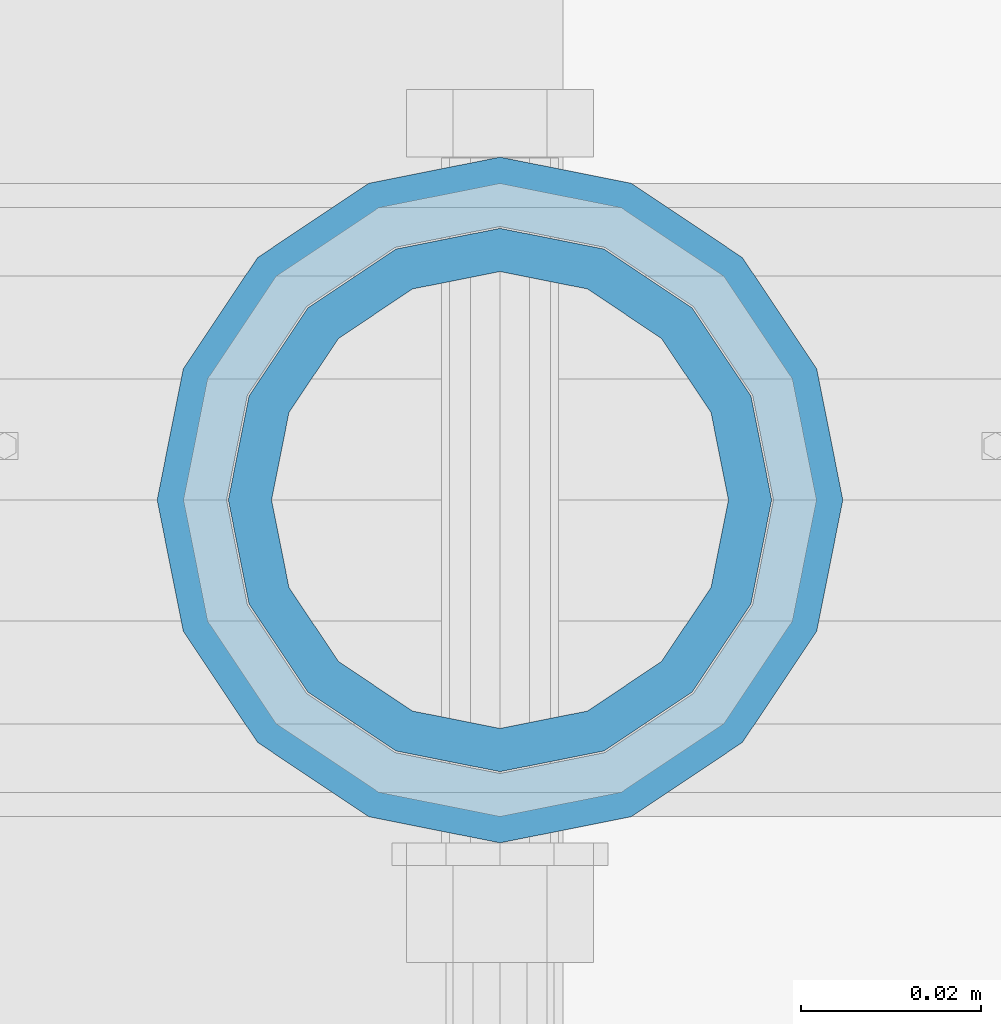
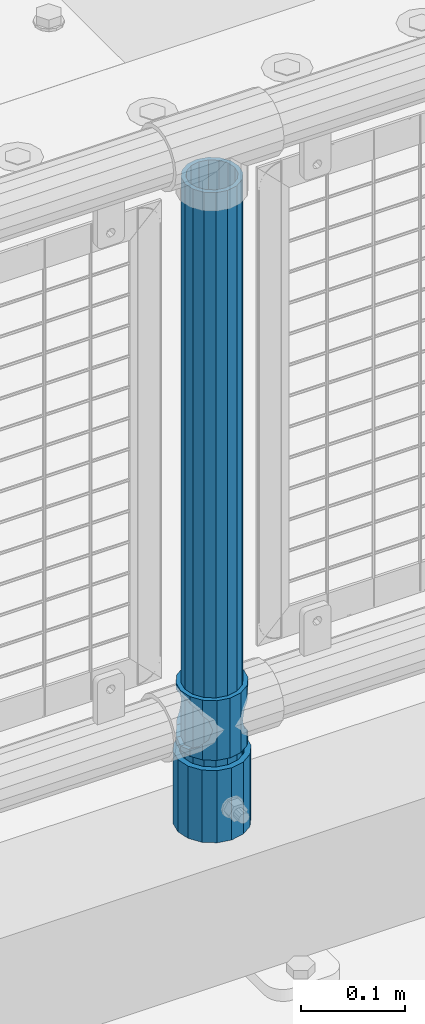
# One storey, part 78 of 219: 3 columns.
"""IFC2X3 building model written with IfcOpenShell, lengths in millimetres."""

from ifc_helpers import new_model, si_unit, frame, origin_with_axes, place, context, subcontext, project, spatial, faceted_brep, material, type_object, element, save


model = new_model("IFC2X3")

# Units and contexts
model_context = context("Model", 3, precision=1e-05, world=origin_with_axes())
body_context = subcontext(model_context, "Body", "Model", "MODEL_VIEW")
ifc_project = project(units=[si_unit("LENGTHUNIT", "METRE", prefix="MILLI"), si_unit("AREAUNIT", "SQUARE_METRE"), si_unit("VOLUMEUNIT", "CUBIC_METRE"), si_unit("MASSUNIT", "GRAM", prefix="KILO"), si_unit("TIMEUNIT", "SECOND"), si_unit("PLANEANGLEUNIT", "RADIAN"), si_unit("SOLIDANGLEUNIT", "STERADIAN"), si_unit("THERMODYNAMICTEMPERATUREUNIT", "DEGREE_CELSIUS"), si_unit("LUMINOUSINTENSITYUNIT", "LUMEN")], contexts=[model_context])

# Site, building, storey
site_placement = place(None, origin_with_axes())
site = spatial("IfcSite", under=ifc_project, at=site_placement, CompositionType="ELEMENT")
building_placement = place(site_placement, origin_with_axes())
building = spatial("IfcBuilding", under=site, at=building_placement, Name="Standard", CompositionType="ELEMENT")
storey_placement = place(building_placement, origin_with_axes())
storey = spatial("IfcBuildingStorey", under=building, at=storey_placement, Name="Undefined", CompositionType="ELEMENT", Elevation=0.0)

# Columns
ifc_material_1 = material(Name="Misc_Undefined")
column_type_1 = type_object("IfcColumnType", PredefinedType="NOTDEFINED")
column_1_placement = place(storey_placement, frame((7253.0, 31664.5, 263.02), z_axis=(-1.0, 0.0, 0.0), x_axis=(0.0, 0.0, 1.0)))
element("IfcColumn", 1, at=column_1_placement, inside=storey, type_object=column_type_1, material=ifc_material_1, context=body_context, shape_type="Brep", body=[
    faceted_brep([(56.6106908090114, 21.46069080901, -21.4606908090118), (56.6106908090114, 21.46069080901, -27.1226768591096), (61.9623795176703, 13.4513226476338, -32.4743655677721), (63.1897438117172, 11.614442172282, -32.8397438117172), (63.1897438117172, 11.614442172282, -28.0397438117179), (46.7644421722801, 28.0397438117179, -11.6144421722802), (46.7644421722801, 28.0397438117179, -20.0882031229849), (51.5310424080006, 24.8548033587067, -24.8548033587067), (35.1499999999996, 30.35, 0.0), (35.1499999999996, 30.3499999999985, -16.6306603983739), (23.5355578277192, 28.0397438117179, -11.6144421722802), (23.5355578277192, 28.0397438117179, -20.0882031229849), (13.6893091909879, 21.46069080901, -21.4606908090118), (13.6893091909879, 21.46069080901, -27.1226768591096), (18.7689575919987, 24.8548033587067, -24.8548033587067), (7.11025618828211, 11.614442172282, -28.0397438117179), (7.11025618828211, 11.614442172282, -32.8397438117172), (8.33762048232455, 13.4513226476338, -32.4743655677721), (4.79999999999961, 0.0, -30.3500000000004), (4.79999999999961, 0.0, -35.1499999999996), (7.11025618828211, -11.614442172282, -28.0397438117179), (7.11025618828211, -11.614442172282, -32.839743811719), (13.6893091909879, -21.46069080901, -21.4606908090118), (13.6893091909879, -21.46069080901, -27.1226768591077), (8.33762048232455, -13.4513226476338, -32.4743655677721), (23.5355578277191, -28.0397438117179, -11.6144421722802), (23.5355578277191, -28.0397438117179, -20.0882031229739), (18.7689575919921, -24.8548033587067, -24.8548033587067), (35.1499999999996, -30.35, 0.0), (35.1499999999996, -30.3499999999985, -16.6306603983649), (46.7644421722801, -28.0397438117179, -11.6144421722802), (46.7644421722801, -28.0397438117179, -20.0882031229739), (56.6106908090114, -21.46069080901, -21.4606908090118), (56.6106908090114, -21.46069080901, -27.1226768591077), (51.5310424080006, -24.8548033587067, -24.8548033587067), (63.1897438117172, -11.614442172282, -28.0397438117179), (63.1897438117172, -11.614442172282, -32.839743811719), (61.9623795176747, -13.4513226476338, -32.4743655677721), (65.4999999999997, 0.0, -30.3500000000004), (65.4999999999997, 0.0, -35.1499999999996), (0.0, -28.0397438117179, -11.6144421722802), (0.0, -30.3499999999985, 0.0), (0.0, -21.46069080901, -21.4606908090118), (0.0, -11.614442172282, -28.0397438117179), (0.0, 0.0, -30.3500000000004), (0.0, 11.614442172282, -28.0397438117179), (0.0, 21.46069080901, -21.4606908090118), (0.0, 28.0397438117179, -11.6144421722802), (0.0, 30.3499999999985, 0.0), (0.0, 28.0397438117179, 11.6144421722802), (23.5355578277192, 28.0397438117179, 11.6144421722806), (0.0, 21.46069080901, 21.4606908090118), (13.6893091909879, 21.46069080901, 21.4606908090118), (0.0, 11.614442172282, 28.0397438117179), (7.11025618828211, 11.614442172282, 28.0397438117175), (0.0, 0.0, 30.3500000000004), (4.79999999999961, 0.0, 30.3499999999999), (0.0, -11.614442172282, 28.0397438117179), (7.11025618828205, -11.614442172282, 28.0397438117175), (0.0, -21.46069080901, 21.4606908090118), (13.6893091909879, -21.46069080901, 21.4606908090118), (0.0, -28.0397438117179, 11.6144421722802), (23.5355578277191, -28.0397438117179, 11.6144421722806), (0.0, -32.4743655677703, 13.4513226476338), (0.0, -35.1500000000015, 0.0), (70.2999999999993, -35.1500000000015, 0.0), (70.2999999999993, -32.4743655677703, 13.4513226476338), (0.0, 13.4513226476338, -32.4743655677721), (0.0, 24.8548033587067, -24.8548033587067), (0.0, 0.0, -35.1500000000015), (0.0, -13.4513226476338, -32.4743655677721), (0.0, -24.8548033587067, -24.8548033587067), (0.0, -24.8548033587067, 24.8548033587067), (0.0, -13.4513226476338, 32.4743655677721), (0.0, 0.0, 35.1500000000015), (0.0, 13.4513226476338, 32.4743655677721), (0.0, 24.8548033587067, 24.8548033587067), (0.0, 32.4743655677703, 13.4513226476338), (0.0, 35.1500000000015, 0.0), (0.0, 32.4743655677703, -13.4513226476338), (0.0, -32.4743655677703, -13.4513226476338), (70.2999999999993, 32.4743655677703, 13.4513226476338), (70.2999999999993, 35.1500000000015, 0.0), (70.2999999999993, 32.4743655677703, -13.4513226476338), (70.2999999999993, 24.8548033587067, -24.8548033587067), (70.2999999999993, 13.4513226476338, -32.4743655677721), (70.2999999999993, 0.0, -35.1499999999996), (70.2999999999993, -13.4513226476338, -32.4743655677721), (70.2999999999993, -24.8548033587067, -24.8548033587067), (70.2999999999993, -32.4743655677703, -13.4513226476338), (70.2999999999993, 28.0397438117179, 11.6144421722802), (70.2999999999993, 21.46069080901, 21.4606908090118), (56.6106908090114, 21.46069080901, 21.4606908090118), (46.7644421722801, 28.0397438117179, 11.6144421722806), (70.2999999999993, 11.614442172282, 28.0397438117179), (63.1897438117172, 11.614442172282, 28.0397438117175), (70.2999999999993, 0.0, 30.3500000000004), (65.4999999999997, 0.0, 30.3499999999999), (70.2999999999993, -11.614442172282, 28.0397438117179), (63.1897438117172, -11.614442172282, 28.0397438117175), (70.2999999999993, -21.46069080901, 21.4606908090118), (56.6106908090114, -21.46069080901, 21.4606908090118), (70.2999999999993, -28.0397438117179, 11.6144421722802), (46.7644421722801, -28.0397438117179, 11.6144421722806), (70.2999999999993, -11.614442172282, -28.0397438117179), (70.2999999999993, 0.0, -30.3500000000004), (70.2999999999993, -21.46069080901, -21.4606908090118), (70.2999999999993, -28.0397438117179, -11.6144421722802), (70.2999999999993, -30.3499999999985, 0.0), (70.2999999999993, 24.8548033587067, 24.8548033587067), (70.2999999999993, 13.4513226476338, 32.4743655677721), (70.2999999999993, 0.0, 35.1499999999996), (70.2999999999993, -13.4513226476338, 32.4743655677721), (70.2999999999993, -24.8548033587067, 24.8548033587067), (70.2999999999993, 30.3499999999985, 0.0), (70.2999999999993, 28.0397438117179, -11.6144421722802), (70.2999999999993, 21.46069080901, -21.4606908090118), (70.2999999999993, 11.614442172282, -28.0397438117179), (61.9623795176742, 13.4513226476338, 32.4743655677717), (51.5310424080006, 24.8548033587067, 24.8548033587072), (56.6106908090114, 21.46069080901, 27.1226768591059), (65.4999999999997, 0.0, 35.1500000000001), (63.1897438117172, 11.614442172282, 32.8397438117177), (63.1897438117172, -11.614442172282, 32.8397438117177), (61.9623795176742, -13.4513226476338, 32.4743655677717), (56.6106908090114, -21.46069080901, 27.1226768591087), (51.5310424080006, -24.8548033587067, 24.8548033587072), (18.7689575919921, -24.8548033587067, 24.8548033587072), (46.7644421722801, -28.0397438117179, 20.0882031229862), (35.1499999999996, -30.3499999999985, 16.630660398373), (23.5355578277191, -28.0397438117179, 20.0882031229862), (8.33762048232506, -13.4513226476338, 32.4743655677717), (13.6893091909879, -21.46069080901, 27.1226768591087), (4.79999999999961, 0.0, 35.1500000000001), (7.11025618828205, -11.614442172282, 32.8397438117177), (7.11025618828211, 11.614442172282, 32.8397438117177), (8.33762048232069, 13.4513226476338, 32.4743655677717), (13.6893091909879, 21.46069080901, 27.1226768591059), (18.7689575919987, 24.8548033587067, 24.8548033587072), (23.5355578277192, 28.0397438117179, 20.0882031229794), (35.1499999999996, 30.3499999999985, 16.6306603983667), (46.7644421722801, 28.0397438117179, 20.0882031229794)], [[[0, 1, 2, 3, 4]], [[5, 6, 7, 1, 0]], [[8, 9, 6, 5]], [[10, 11, 9, 8]], [[12, 13, 14, 11, 10]], [[15, 16, 17, 13, 12]], [[18, 19, 16, 15]], [[20, 21, 19, 18]], [[22, 23, 24, 21, 20]], [[25, 26, 27, 23, 22]], [[28, 29, 26, 25]], [[30, 31, 29, 28]], [[32, 33, 34, 31, 30]], [[35, 36, 37, 33, 32]], [[38, 39, 36, 35]], [[4, 3, 39, 38]], [[40, 41, 28, 25]], [[42, 40, 25, 22]], [[43, 42, 22, 20]], [[44, 43, 20, 18]], [[45, 44, 18, 15]], [[46, 45, 15, 12]], [[47, 46, 12, 10]], [[48, 47, 10, 8]], [[49, 48, 8, 50]], [[51, 49, 50, 52]], [[53, 51, 52, 54]], [[55, 53, 54, 56]], [[57, 55, 56, 58]], [[59, 57, 58, 60]], [[61, 59, 60, 62]], [[41, 61, 62, 28]], [[63, 64, 65, 66]], [[17, 67, 68, 14, 13]], [[19, 69, 67, 17, 16]], [[70, 69, 19, 21, 24]], [[71, 70, 24, 23, 27]], [[63, 72, 73, 74, 75, 76, 77, 78, 79, 68, 67, 69, 70, 71, 80, 64], [40, 42, 43, 44, 45, 46, 47, 48, 49, 51, 53, 55, 57, 59, 61, 41]], [[78, 77, 81, 82]], [[79, 78, 82, 83]], [[14, 68, 79, 83, 84, 7, 6, 9, 11]], [[84, 85, 2, 1, 7]], [[85, 86, 39, 3, 2]], [[37, 87, 88, 34, 33]], [[39, 86, 87, 37, 36]], [[34, 88, 89, 80, 71, 27, 26, 29, 31]], [[64, 80, 89, 65]], [[90, 91, 92, 93]], [[91, 94, 95, 92]], [[94, 96, 97, 95]], [[96, 98, 99, 97]], [[98, 100, 101, 99]], [[100, 102, 103, 101]], [[104, 105, 38, 35]], [[106, 104, 35, 32]], [[107, 106, 32, 30]], [[108, 107, 30, 28]], [[102, 108, 28, 103]], [[88, 87, 86, 85, 84, 83, 82, 81, 109, 110, 111, 112, 113, 66, 65, 89], [100, 98, 96, 94, 91, 90, 114, 115, 116, 117, 105, 104, 106, 107, 108, 102]], [[118, 110, 109, 119, 120]], [[121, 111, 110, 118, 122]], [[112, 111, 121, 123, 124]], [[113, 112, 124, 125, 126]], [[127, 72, 63, 66, 113, 126, 128, 129, 130]], [[131, 73, 72, 127, 132]], [[133, 74, 73, 131, 134]], [[75, 74, 133, 135, 136]], [[76, 75, 136, 137, 138]], [[119, 109, 81, 77, 76, 138, 139, 140, 141]], [[92, 120, 119, 141, 93]], [[95, 122, 118, 120, 92]], [[97, 121, 122, 95]], [[99, 123, 121, 97]], [[101, 125, 124, 123, 99]], [[103, 128, 126, 125, 101]], [[28, 129, 128, 103]], [[62, 130, 129, 28]], [[60, 132, 127, 130, 62]], [[58, 134, 131, 132, 60]], [[56, 133, 134, 58]], [[54, 135, 133, 56]], [[52, 137, 136, 135, 54]], [[50, 139, 138, 137, 52]], [[8, 140, 139, 50]], [[93, 141, 140, 8]], [[114, 90, 93, 8]], [[115, 114, 8, 5]], [[116, 115, 5, 0]], [[117, 116, 0, 4]], [[105, 117, 4, 38]]]),
])
ifc_material_2 = material()
column_type_2 = type_object("IfcColumnType", PredefinedType="NOTDEFINED")
column_2_placement = place(storey_placement, frame((7253.0, 31664.5, 168.02), z_axis=(-1.0, 0.0, 0.0), x_axis=(0.0, 0.0, 1.0)))
element("IfcColumn", 2, at=column_2_placement, inside=storey, type_object=column_type_2, material=ifc_material_2, context=body_context, shape_type="Brep", body=[
    faceted_brep([(0.0, -25.3499999999985, 0.0), (0.0, -23.4203461491597, 9.70102501045585), (760.0, -23.4203461491597, 9.70102501045585), (760.0, -25.3499999999985, 0.0), (0.0, -17.9251569030785, 17.9251569030785), (760.0, -17.9251569030785, 17.9251569030785), (0.0, -9.70102501045403, 23.4203461491616), (760.0, -9.70102501045403, 23.4203461491616), (0.0, 0.0, 25.3500000000004), (760.0, 0.0, 25.3500000000004), (0.0, 9.70102501045403, 23.4203461491616), (760.0, 9.70102501045403, 23.4203461491616), (0.0, 17.9251569030785, 17.9251569030785), (760.0, 17.9251569030785, 17.9251569030785), (0.0, 23.4203461491597, 9.70102501045585), (760.0, 23.4203461491597, 9.70102501045585), (0.0, 25.3499999999985, 0.0), (760.0, 25.3499999999985, 0.0), (0.0, 23.4203461491597, -9.70102501045585), (760.0, 23.4203461491597, -9.70102501045585), (0.0, 17.9251569030785, -17.9251569030785), (760.0, 17.9251569030785, -17.9251569030785), (0.0, 9.70102501045403, -23.4203461491616), (760.0, 9.70102501045403, -23.4203461491616), (0.0, 0.0, -25.3500000000004), (760.0, 0.0, -25.3500000000004), (0.0, -9.70102501045403, -23.4203461491616), (760.0, -9.70102501045403, -23.4203461491616), (0.0, -17.9251569030785, -17.9251569030785), (760.0, -17.9251569030785, -17.9251569030785), (0.0, -23.4203461491597, -9.70102501045585), (760.0, -23.4203461491597, -9.70102501045585), (0.0, -30.1500000000015, 0.0), (0.0, -27.8549679052157, -11.5379054858076), (760.0, -27.8549679052157, -11.5379054858076), (760.0, -30.1500000000015, 0.0), (0.0, -21.3192694527752, -21.3192694527752), (760.0, -21.3192694527752, -21.3192694527752), (0.0, -11.5379054858058, -27.8549679052157), (760.0, -11.5379054858058, -27.8549679052157), (0.0, 0.0, -30.1499999999996), (760.0, 0.0, -30.1499999999996), (0.0, 11.5379054858058, -27.8549679052157), (760.0, 11.5379054858058, -27.8549679052157), (0.0, 21.3192694527752, -21.3192694527752), (760.0, 21.3192694527752, -21.3192694527752), (0.0, 27.8549679052157, -11.5379054858076), (760.0, 27.8549679052157, -11.5379054858076), (0.0, 30.1500000000015, 0.0), (760.0, 30.1500000000015, 0.0), (0.0, 27.8549679052157, 11.5379054858076), (760.0, 27.8549679052157, 11.5379054858076), (0.0, 21.3192694527752, 21.3192694527752), (760.0, 21.3192694527752, 21.3192694527752), (0.0, 11.5379054858058, 27.8549679052157), (760.0, 11.5379054858058, 27.8549679052157), (0.0, 0.0, 30.1499999999996), (760.0, 0.0, 30.1499999999996), (0.0, -11.5379054858058, 27.8549679052157), (760.0, -11.5379054858058, 27.8549679052157), (0.0, -21.3192694527752, 21.3192694527752), (760.0, -21.3192694527752, 21.3192694527752), (0.0, -27.8549679052157, 11.5379054858076), (760.0, -27.8549679052157, 11.5379054858076)], [[[0, 1, 2, 3]], [[1, 4, 5, 2]], [[4, 6, 7, 5]], [[6, 8, 9, 7]], [[8, 10, 11, 9]], [[10, 12, 13, 11]], [[12, 14, 15, 13]], [[14, 16, 17, 15]], [[16, 18, 19, 17]], [[18, 20, 21, 19]], [[20, 22, 23, 21]], [[22, 24, 25, 23]], [[24, 26, 27, 25]], [[26, 28, 29, 27]], [[28, 30, 31, 29]], [[30, 0, 3, 31]], [[32, 33, 34, 35]], [[33, 36, 37, 34]], [[36, 38, 39, 37]], [[38, 40, 41, 39]], [[40, 42, 43, 41]], [[42, 44, 45, 43]], [[44, 46, 47, 45]], [[46, 48, 49, 47]], [[48, 50, 51, 49]], [[50, 52, 53, 51]], [[52, 54, 55, 53]], [[54, 56, 57, 55]], [[56, 58, 59, 57]], [[58, 60, 61, 59]], [[60, 62, 63, 61]], [[62, 32, 35, 63]], [[37, 39, 41, 43, 45, 47, 49, 51, 53, 55, 57, 59, 61, 63, 35, 34], [5, 7, 9, 11, 13, 15, 17, 19, 21, 23, 25, 27, 29, 31, 3, 2]], [[62, 60, 58, 56, 54, 52, 50, 48, 46, 44, 42, 40, 38, 36, 33, 32], [30, 28, 26, 24, 22, 20, 18, 16, 14, 12, 10, 8, 6, 4, 1, 0]]]),
])
column_type_3 = type_object("IfcColumnType", PredefinedType="NOTDEFINED")
column_3_placement = place(storey_placement, frame((7253.0, 31664.5, 168.02), z_axis=(0.0, 1.0, 0.0), x_axis=(0.0, 0.0, 1.0)))
element("IfcColumn", 3, at=column_3_placement, inside=storey, type_object=column_type_3, material=ifc_material_2, context=body_context, shape_type="Brep", body=[
    faceted_brep([(0.0, -31.75, 0.0), (0.0, -29.3331751572332, 12.1501989775934), (85.0, -29.3331751572332, 12.1501989775934), (85.0, -31.75, 0.0), (0.0, -22.4506403026735, 22.4506403026717), (85.0, -22.4506403026735, 22.4506403026717), (0.0, -12.1501989775916, 29.3331751572332), (85.0, -12.1501989775916, 29.3331751572332), (0.0, 0.0, 31.75), (85.0, 0.0, 31.75), (0.0, 12.1501989775916, 29.3331751572332), (85.0, 12.1501989775916, 29.3331751572332), (0.0, 22.4506403026735, 22.4506403026717), (85.0, 22.4506403026735, 22.4506403026717), (0.0, 29.3331751572332, 12.1501989775934), (85.0, 29.3331751572332, 12.1501989775934), (0.0, 31.75, 0.0), (85.0, 31.75, 0.0), (0.0, 29.3331751572332, -12.1501989775934), (85.0, 29.3331751572332, -12.1501989775934), (0.0, 22.4506403026735, -22.4506403026717), (85.0, 22.4506403026735, -22.4506403026717), (0.0, 12.1501989775916, -29.3331751572332), (85.0, 12.1501989775916, -29.3331751572332), (0.0, 0.0, -31.75), (85.0, 0.0, -31.75), (0.0, -12.1501989775916, -29.3331751572332), (85.0, -12.1501989775916, -29.3331751572332), (0.0, -22.4506403026735, -22.4506403026717), (85.0, -22.4506403026735, -22.4506403026717), (0.0, -29.3331751572332, -12.1501989775934), (85.0, -29.3331751572332, -12.1501989775934), (0.0, -38.0499999999993, 0.0), (0.0, -35.1536162120537, -14.5611046014928), (85.0, -35.1536162120537, -14.5611046014928), (85.0, -38.0499999999993, 0.0), (0.0, -26.9054130241475, -26.9054130241493), (85.0, -26.9054130241475, -26.9054130241493), (0.0, -14.561104601491, -35.1536162120537), (85.0, -14.561104601491, -35.1536162120537), (0.0, 0.0, -38.0499999999993), (85.0, 0.0, -38.0499999999993), (0.0, 14.561104601491, -35.1536162120537), (85.0, 14.561104601491, -35.1536162120537), (0.0, 26.9054130241475, -26.9054130241493), (85.0, 26.9054130241475, -26.9054130241493), (0.0, 35.1536162120537, -14.5611046014928), (85.0, 35.1536162120537, -14.5611046014928), (0.0, 38.0499999999993, 0.0), (85.0, 38.0499999999993, 0.0), (0.0, 35.1536162120537, 14.5611046014928), (85.0, 35.1536162120537, 14.5611046014928), (0.0, 26.9054130241475, 26.9054130241493), (85.0, 26.9054130241475, 26.9054130241493), (0.0, 14.561104601491, 35.1536162120537), (85.0, 14.561104601491, 35.1536162120537), (0.0, 0.0, 38.0499999999993), (85.0, 0.0, 38.0499999999993), (0.0, -14.561104601491, 35.1536162120537), (85.0, -14.561104601491, 35.1536162120537), (0.0, -26.9054130241475, 26.9054130241493), (85.0, -26.9054130241475, 26.9054130241493), (0.0, -35.1536162120537, 14.5611046014928), (85.0, -35.1536162120537, 14.5611046014928)], [[[0, 1, 2, 3]], [[1, 4, 5, 2]], [[4, 6, 7, 5]], [[6, 8, 9, 7]], [[8, 10, 11, 9]], [[10, 12, 13, 11]], [[12, 14, 15, 13]], [[14, 16, 17, 15]], [[16, 18, 19, 17]], [[18, 20, 21, 19]], [[20, 22, 23, 21]], [[22, 24, 25, 23]], [[24, 26, 27, 25]], [[26, 28, 29, 27]], [[28, 30, 31, 29]], [[30, 0, 3, 31]], [[32, 33, 34, 35]], [[33, 36, 37, 34]], [[36, 38, 39, 37]], [[38, 40, 41, 39]], [[40, 42, 43, 41]], [[42, 44, 45, 43]], [[44, 46, 47, 45]], [[46, 48, 49, 47]], [[48, 50, 51, 49]], [[50, 52, 53, 51]], [[52, 54, 55, 53]], [[54, 56, 57, 55]], [[56, 58, 59, 57]], [[58, 60, 61, 59]], [[60, 62, 63, 61]], [[62, 32, 35, 63]], [[37, 39, 41, 43, 45, 47, 49, 51, 53, 55, 57, 59, 61, 63, 35, 34], [5, 7, 9, 11, 13, 15, 17, 19, 21, 23, 25, 27, 29, 31, 3, 2]], [[62, 60, 58, 56, 54, 52, 50, 48, 46, 44, 42, 40, 38, 36, 33, 32], [30, 28, 26, 24, 22, 20, 18, 16, 14, 12, 10, 8, 6, 4, 1, 0]]]),
])

save(model, "model.ifc")
